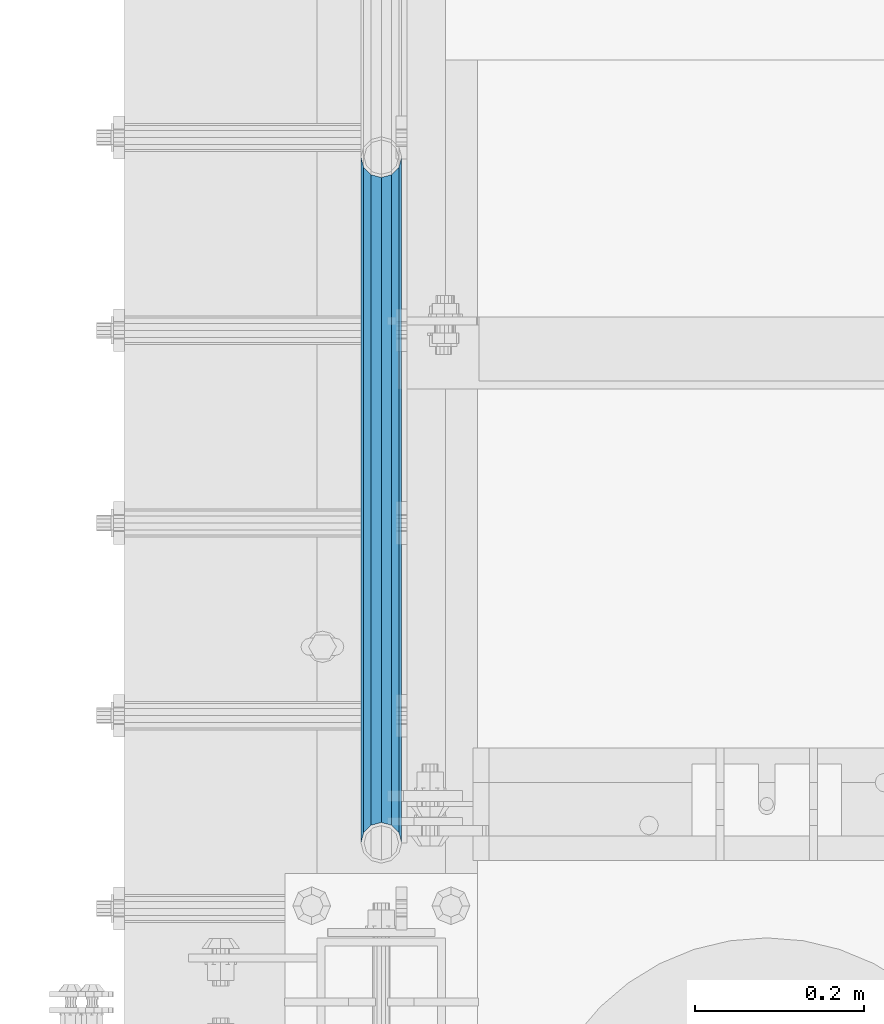
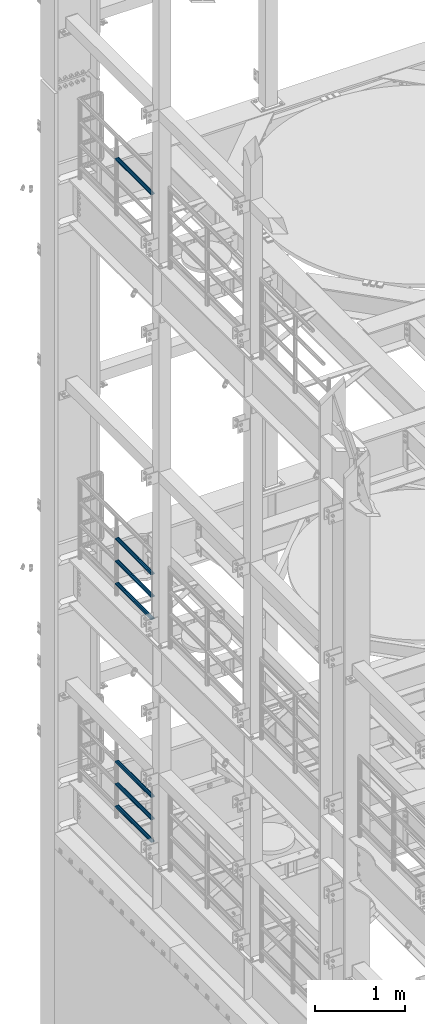
# One storey, part 1312 of 1876: 7 beams, 3 elements without a shape of their own.
"""IFC2X3 building model written with IfcOpenShell, lengths in millimetres."""

from ifc_helpers import new_model, si_unit, frame, origin_with_axes, place, context, subcontext, project, spatial, faceted_brep, material, type_object, element, aggregate, save


model = new_model("IFC2X3")

# Units and contexts
model_context = context("Model", 3, precision=1e-05, world=origin_with_axes())
body_context = subcontext(model_context, "Body", "Model", "MODEL_VIEW")
ifc_project = project(units=[si_unit("LENGTHUNIT", "METRE", prefix="MILLI"), si_unit("AREAUNIT", "SQUARE_METRE"), si_unit("VOLUMEUNIT", "CUBIC_METRE"), si_unit("MASSUNIT", "GRAM", prefix="KILO"), si_unit("TIMEUNIT", "SECOND"), si_unit("PLANEANGLEUNIT", "RADIAN"), si_unit("SOLIDANGLEUNIT", "STERADIAN"), si_unit("THERMODYNAMICTEMPERATUREUNIT", "DEGREE_CELSIUS"), si_unit("LUMINOUSINTENSITYUNIT", "LUMEN")], contexts=[model_context])

# Site, building, storey
site_placement = place(None, origin_with_axes())
site = spatial("IfcSite", under=ifc_project, at=site_placement, CompositionType="ELEMENT")
building_placement = place(site_placement, origin_with_axes())
building = spatial("IfcBuilding", under=site, at=building_placement, Name="Undefined", CompositionType="ELEMENT")
storey_placement = place(building_placement, origin_with_axes())
storey = spatial("IfcBuildingStorey", under=building, at=storey_placement, Name="Undefined", CompositionType="ELEMENT", Elevation=0.0)

# Assembly, beam
assembly_1_placement = place(storey_placement, origin_with_axes())
assembly_1 = element("IfcElementAssembly", 1, at=assembly_1_placement, inside=storey, Name="RAIL", AssemblyPlace="NOTDEFINED", PredefinedType="RIGID_FRAME")
ifc_material = material()
beam_type = type_object("IfcBeamType", Name="PIPE1-1/2SCH40", PredefinedType="NOTDEFINED")
beam_1_placement = place(assembly_1_placement, frame((-3.11501935357228e-11, 11872.9125, 14081.125), z_axis=(0.0, 0.0, -1.0), x_axis=(0.0, 1.0, 0.0)))
beam_1 = element("IfcBeam", 2, at=beam_1_placement, type_object=beam_type, material=ifc_material, Name="RAIL", ObjectType="PIPE1-1/2SCH40", context=body_context, shape_type="Brep", body=[
    faceted_brep([(0.0, 24.1299999999992, 0.0), (12.0650000000064, 20.8971929933177, -12.0649999999987), (12.0650000000064, 20.8971929933177, 12.0649999999987), (12.0650000000064, -20.8971929933177, 12.0649999999987), (12.0650000000064, -20.8971929933177, -12.0649999999987), (0.0, -24.1299999999992, 0.0), (20.8971929933249, -12.0650000000005, 20.8971929933177), (20.8971929933249, -12.0650000000005, 15.8661214311796), (15.2545715621445, -17.7076214311801, 10.2235000000001), (12.5151929933249, -20.4470000000001, 0.0), (15.2545715621445, -17.7076214311801, -10.2235000000001), (20.8971929933249, -12.0650000000005, -15.8661214311796), (20.8971929933249, -12.0650000000005, -20.8971929933177), (24.1300000000063, 0.0, -20.4470000000001), (24.1300000000063, 0.0, -24.130000000001), (21.3906214311868, -10.2235000000001, -17.7076214311819), (21.3906214311868, 10.2235000000001, -17.7076214311819), (20.8971929933249, 12.0650000000005, -15.8661214311796), (20.8971929933249, 12.0650000000005, -20.8971929933177), (15.2545715621445, 17.7076214311801, -10.2235000000001), (12.5151929933249, 20.4470000000001, 0.0), (15.2545715621445, 17.7076214311801, 10.2235000000001), (20.8971929933249, 12.0650000000005, 15.8661214311796), (20.8971929933249, 12.0650000000005, 20.8971929933177), (21.3906214311868, 10.2235000000001, 17.7076214311819), (24.1300000000064, 0.0, 20.4470000000001), (24.1300000000064, 0.0, 24.130000000001), (21.3906214311868, -10.2235000000001, 17.7076214311819), (813.396900000002, 24.1300000000001, 0.0), (801.331900000001, 20.8971929933186, -12.0649999999987), (792.499707006684, 12.0649999999996, -20.8971929933177), (813.396900000002, -24.1300000000319, 0.0), (801.331900000001, -20.8971929933186, -12.0649999999987), (801.331900000001, -20.8971929933186, 12.0649999999987), (792.499707006684, -12.0649999999996, 20.8971929933177), (792.499707006684, -12.0649999999996, -20.8971929933177), (789.266900000001, 0.0, -24.130000000001), (792.00627856883, 10.2235000000001, -17.7076214311819), (789.266900000001, 0.0, -20.4470000000001), (792.499707006684, 12.0649999999678, -15.8661214312124), (792.499707006684, -12.0650000000314, -15.8661214311469), (792.006278568813, -10.2235000000001, -17.7076214311819), (798.142328437831, -17.7076214311801, -10.2235000000001), (800.881707006651, -20.4470000000001, 0.0), (798.142328437831, -17.7076214311801, 10.2235000000001), (792.499707006684, -12.0650000000314, 15.8661214311469), (792.006278568813, -10.2235000000001, 17.7076214311819), (789.266900000001, -9.09494701772928e-13, 20.4470000000001), (789.266900000001, -9.09494701772928e-13, 24.130000000001), (792.499707006684, 12.0649999999996, 20.8971929933177), (801.331900000001, 20.8971929933186, 12.0649999999987), (792.499707006684, 12.0649999999678, 15.8661214312124), (798.142328437896, 17.7076214311801, 10.2235000000001), (800.881707006714, 20.4470000000001, 0.0), (798.142328437896, 17.7076214311801, -10.2235000000001), (792.00627856883, 10.2235000000001, 17.7076214311819)], [[[0, 1, 2]], [[3, 4, 5]], [[6, 7, 8, 9, 10, 11, 12, 4, 3]], [[13, 14, 12, 11, 15]], [[16, 17, 18, 14, 13]], [[2, 1, 18, 17, 19, 20, 21, 22, 23]], [[23, 22, 24, 25, 26]], [[26, 25, 27, 7, 6]], [[1, 0, 28, 29]], [[18, 1, 29, 30]], [[31, 32, 33]], [[6, 3, 33, 34]], [[3, 5, 31, 33]], [[5, 4, 32, 31]], [[4, 12, 35, 32]], [[12, 14, 36, 35]], [[14, 18, 30, 36]], [[37, 38, 36, 30, 39]], [[40, 35, 36, 38, 41]], [[33, 32, 35, 40, 42, 43, 44, 45, 34]], [[34, 45, 46, 47, 48]], [[26, 6, 34, 48]], [[2, 23, 49, 50]], [[23, 26, 48, 49]], [[0, 2, 50, 28]], [[28, 50, 29]], [[49, 51, 52, 53, 54, 39, 30, 29, 50]], [[48, 47, 55, 51, 49]], [[25, 24, 55, 47]], [[55, 24, 22, 21, 52, 51]], [[21, 20, 53, 52]], [[20, 19, 54, 53]], [[19, 17, 16, 37, 39, 54]], [[16, 13, 38, 37]], [[13, 15, 41, 38]], [[41, 15, 11, 10, 42, 40]], [[10, 9, 43, 42]], [[9, 8, 44, 43]], [[8, 7, 27, 46, 45, 44]], [[27, 25, 47, 46]]]),
])
aggregate(assembly_1, [beam_1])

# Assembly, beams
assembly_2_placement = place(storey_placement, origin_with_axes())
assembly_2 = element("IfcElementAssembly", 3, at=assembly_2_placement, inside=storey, Name="RAIL", AssemblyPlace="NOTDEFINED", PredefinedType="RIGID_FRAME")
beam_2_placement = place(assembly_2_placement, frame((-3.02406988339499e-11, 12686.3094, 8315.325), z_axis=(0.0, 0.0, 1.0), x_axis=(0.0, -1.0, 0.0)))
beam_2 = element("IfcBeam", 4, at=beam_2_placement, type_object=beam_type, material=ifc_material, Name="RAIL", ObjectType="PIPE1-1/2SCH40", context=body_context, shape_type="Brep", body=[
    faceted_brep([(792.499707006684, -12.0649999999996, 20.8971929933177), (792.499707006684, -12.0650000000314, 15.8661214311469), (792.006278568813, -10.2235000000001, 17.7076214311819), (789.266900000001, -9.09494701772928e-13, 20.4470000000001), (789.266900000001, -9.09494701772928e-13, 24.130000000001), (792.00627856883, 10.2235000000001, 17.7076214311819), (792.499707006684, 12.0649999999678, 15.8661214312124), (792.499707006684, 12.0649999999996, 20.8971929933177), (813.396900000002, 24.1300000000001, 0.0), (801.331900000001, 20.8971929933186, 12.0649999999987), (801.331900000001, 20.8971929933186, -12.0649999999987), (798.142328437896, 17.7076214311801, 10.2235000000001), (800.881707006714, 20.4470000000001, 0.0), (798.142328437896, 17.7076214311801, -10.2235000000001), (792.499707006684, 12.0649999999678, -15.8661214312124), (792.499707006684, 12.0649999999996, -20.8971929933177), (792.00627856883, 10.2235000000001, -17.7076214311819), (789.266900000001, 0.0, -20.4470000000001), (789.266900000001, 0.0, -24.130000000001), (792.499707006684, -12.0650000000314, -15.8661214311469), (792.499707006684, -12.0649999999996, -20.8971929933177), (792.006278568813, -10.2235000000001, -17.7076214311819), (813.396900000002, -24.1300000000319, 0.0), (801.331900000001, -20.8971929933186, -12.0649999999987), (801.331900000001, -20.8971929933186, 12.0649999999987), (798.142328437831, -17.7076214311801, -10.2235000000001), (800.881707006651, -20.4470000000001, 0.0), (798.142328437831, -17.7076214311801, 10.2235000000001), (12.0650000000064, -20.8971929933177, -12.0649999999987), (20.8971929933249, -12.0650000000005, -20.8971929933177), (0.0, 24.1299999999992, 0.0), (12.0650000000064, 20.8971929933177, -12.0649999999987), (12.0650000000064, 20.8971929933177, 12.0649999999987), (20.8971929933249, 12.0650000000005, 20.8971929933177), (24.1300000000064, 0.0, 24.130000000001), (20.8971929933249, 12.0650000000005, -20.8971929933177), (24.1300000000063, 0.0, -24.130000000001), (24.1300000000063, 0.0, -20.4470000000001), (20.8971929933249, -12.0650000000005, -15.8661214311796), (21.3906214311868, -10.2235000000001, -17.7076214311819), (21.3906214311868, 10.2235000000001, -17.7076214311819), (20.8971929933249, 12.0650000000005, -15.8661214311796), (15.2545715621445, 17.7076214311801, -10.2235000000001), (12.5151929933249, 20.4470000000001, 0.0), (15.2545715621445, 17.7076214311801, 10.2235000000001), (20.8971929933249, 12.0650000000005, 15.8661214311796), (21.3906214311868, 10.2235000000001, 17.7076214311819), (24.1300000000064, 0.0, 20.4470000000001), (21.3906214311868, -10.2235000000001, 17.7076214311819), (20.8971929933249, -12.0650000000005, 15.8661214311796), (20.8971929933249, -12.0650000000005, 20.8971929933177), (12.0650000000064, -20.8971929933177, 12.0649999999987), (0.0, -24.1299999999992, 0.0), (15.2545715621445, -17.7076214311801, 10.2235000000001), (12.5151929933249, -20.4470000000001, 0.0), (15.2545715621445, -17.7076214311801, -10.2235000000001)], [[[0, 1, 2, 3, 4]], [[4, 3, 5, 6, 7]], [[8, 9, 10]], [[7, 6, 11, 12, 13, 14, 15, 10, 9]], [[16, 17, 18, 15, 14]], [[19, 20, 18, 17, 21]], [[22, 23, 24]], [[24, 23, 20, 19, 25, 26, 27, 1, 0]], [[28, 29, 20, 23]], [[30, 31, 32]], [[33, 34, 4, 7]], [[32, 33, 7, 9]], [[30, 32, 9, 8]], [[31, 30, 8, 10]], [[35, 31, 10, 15]], [[36, 35, 15, 18]], [[29, 36, 18, 20]], [[37, 36, 29, 38, 39]], [[40, 41, 35, 36, 37]], [[32, 31, 35, 41, 42, 43, 44, 45, 33]], [[33, 45, 46, 47, 34]], [[34, 47, 48, 49, 50]], [[34, 50, 0, 4]], [[50, 51, 24, 0]], [[51, 52, 22, 24]], [[52, 28, 23, 22]], [[51, 28, 52]], [[50, 49, 53, 54, 55, 38, 29, 28, 51]], [[55, 54, 26, 25]], [[21, 39, 38, 55, 25, 19]], [[37, 39, 21, 17]], [[40, 37, 17, 16]], [[42, 41, 40, 16, 14, 13]], [[43, 42, 13, 12]], [[44, 43, 12, 11]], [[5, 46, 45, 44, 11, 6]], [[47, 46, 5, 3]], [[48, 47, 3, 2]], [[53, 49, 48, 2, 1, 27]], [[54, 53, 27, 26]]]),
])
beam_3_placement = place(assembly_2_placement, frame((-3.11501935357228e-11, 11872.9125, 8620.125), z_axis=(0.0, 0.0, -1.0), x_axis=(0.0, 1.0, 0.0)))
beam_3 = element("IfcBeam", 5, at=beam_3_placement, type_object=beam_type, material=ifc_material, Name="RAIL", ObjectType="PIPE1-1/2SCH40", context=body_context, shape_type="Brep", body=[
    faceted_brep([(0.0, 24.1299999999992, 0.0), (12.0650000000064, 20.8971929933177, -12.0649999999987), (12.0650000000064, 20.8971929933177, 12.0649999999987), (12.0650000000064, -20.8971929933177, 12.0649999999987), (12.0650000000064, -20.8971929933177, -12.0649999999987), (0.0, -24.1299999999992, 0.0), (20.8971929933249, -12.0650000000005, 20.8971929933177), (20.8971929933249, -12.0650000000005, 15.8661214311796), (15.2545715621445, -17.7076214311801, 10.2235000000001), (12.5151929933249, -20.4470000000001, 0.0), (15.2545715621445, -17.7076214311801, -10.2235000000001), (20.8971929933249, -12.0650000000005, -15.8661214311796), (20.8971929933249, -12.0650000000005, -20.8971929933177), (24.1300000000063, 0.0, -20.4470000000001), (24.1300000000063, 0.0, -24.130000000001), (21.3906214311868, -10.2235000000001, -17.7076214311819), (21.3906214311868, 10.2235000000001, -17.7076214311819), (20.8971929933249, 12.0650000000005, -15.8661214311796), (20.8971929933249, 12.0650000000005, -20.8971929933177), (15.2545715621445, 17.7076214311801, -10.2235000000001), (12.5151929933249, 20.4470000000001, 0.0), (15.2545715621445, 17.7076214311801, 10.2235000000001), (20.8971929933249, 12.0650000000005, 15.8661214311796), (20.8971929933249, 12.0650000000005, 20.8971929933177), (21.3906214311868, 10.2235000000001, 17.7076214311819), (24.1300000000064, 0.0, 20.4470000000001), (24.1300000000064, 0.0, 24.130000000001), (21.3906214311868, -10.2235000000001, 17.7076214311819), (813.396900000002, 24.1300000000001, 0.0), (801.331900000001, 20.8971929933186, -12.0649999999987), (792.499707006684, 12.0649999999996, -20.8971929933177), (813.396900000002, -24.1300000000319, 0.0), (801.331900000001, -20.8971929933186, -12.0649999999987), (801.331900000001, -20.8971929933186, 12.0649999999987), (792.499707006684, -12.0649999999996, 20.8971929933177), (792.499707006684, -12.0649999999996, -20.8971929933177), (789.266900000001, 0.0, -24.130000000001), (792.00627856883, 10.2235000000001, -17.7076214311819), (789.266900000001, 0.0, -20.4470000000001), (792.499707006684, 12.0649999999678, -15.8661214312124), (792.499707006684, -12.0650000000314, -15.8661214311469), (792.006278568813, -10.2235000000001, -17.7076214311819), (798.142328437831, -17.7076214311801, -10.2235000000001), (800.881707006651, -20.4470000000001, 0.0), (798.142328437831, -17.7076214311801, 10.2235000000001), (792.499707006684, -12.0650000000314, 15.8661214311469), (792.006278568813, -10.2235000000001, 17.7076214311819), (789.266900000001, -9.09494701772928e-13, 20.4470000000001), (789.266900000001, -9.09494701772928e-13, 24.130000000001), (792.499707006684, 12.0649999999996, 20.8971929933177), (801.331900000001, 20.8971929933186, 12.0649999999987), (792.499707006684, 12.0649999999678, 15.8661214312124), (798.142328437896, 17.7076214311801, 10.2235000000001), (800.881707006714, 20.4470000000001, 0.0), (798.142328437896, 17.7076214311801, -10.2235000000001), (792.00627856883, 10.2235000000001, 17.7076214311819)], [[[0, 1, 2]], [[3, 4, 5]], [[6, 7, 8, 9, 10, 11, 12, 4, 3]], [[13, 14, 12, 11, 15]], [[16, 17, 18, 14, 13]], [[2, 1, 18, 17, 19, 20, 21, 22, 23]], [[23, 22, 24, 25, 26]], [[26, 25, 27, 7, 6]], [[1, 0, 28, 29]], [[18, 1, 29, 30]], [[31, 32, 33]], [[6, 3, 33, 34]], [[3, 5, 31, 33]], [[5, 4, 32, 31]], [[4, 12, 35, 32]], [[12, 14, 36, 35]], [[14, 18, 30, 36]], [[37, 38, 36, 30, 39]], [[40, 35, 36, 38, 41]], [[33, 32, 35, 40, 42, 43, 44, 45, 34]], [[34, 45, 46, 47, 48]], [[26, 6, 34, 48]], [[2, 23, 49, 50]], [[23, 26, 48, 49]], [[0, 2, 50, 28]], [[28, 50, 29]], [[49, 51, 52, 53, 54, 39, 30, 29, 50]], [[48, 47, 55, 51, 49]], [[25, 24, 55, 47]], [[55, 24, 22, 21, 52, 51]], [[21, 20, 53, 52]], [[20, 19, 54, 53]], [[19, 17, 16, 37, 39, 54]], [[16, 13, 38, 37]], [[13, 15, 41, 38]], [[41, 15, 11, 10, 42, 40]], [[10, 9, 43, 42]], [[9, 8, 44, 43]], [[8, 7, 27, 46, 45, 44]], [[27, 25, 47, 46]]]),
])
beam_4_placement = place(assembly_2_placement, frame((-3.11501935357228e-11, 11872.9125, 8924.925), z_axis=(0.0, 0.0, -1.0), x_axis=(0.0, 1.0, 0.0)))
beam_4 = element("IfcBeam", 6, at=beam_4_placement, type_object=beam_type, material=ifc_material, Name="RAIL", ObjectType="PIPE1-1/2SCH40", context=body_context, shape_type="Brep", body=[
    faceted_brep([(0.0, 24.1299999999992, 0.0), (12.0650000000064, 20.8971929933177, -12.0649999999987), (12.0650000000064, 20.8971929933177, 12.0649999999987), (12.0650000000064, -20.8971929933177, 12.0649999999987), (12.0650000000064, -20.8971929933177, -12.0649999999987), (0.0, -24.1299999999992, 0.0), (20.8971929933249, -12.0650000000005, 20.8971929933177), (20.8971929933249, -12.0650000000005, 15.8661214311796), (15.2545715621445, -17.7076214311801, 10.2235000000001), (12.5151929933249, -20.4470000000001, 0.0), (15.2545715621445, -17.7076214311801, -10.2235000000001), (20.8971929933249, -12.0650000000005, -15.8661214311796), (20.8971929933249, -12.0650000000005, -20.8971929933177), (24.1300000000063, 0.0, -20.4470000000001), (24.1300000000063, 0.0, -24.130000000001), (21.3906214311868, -10.2235000000001, -17.7076214311819), (21.3906214311868, 10.2235000000001, -17.7076214311819), (20.8971929933249, 12.0650000000005, -15.8661214311796), (20.8971929933249, 12.0650000000005, -20.8971929933177), (15.2545715621445, 17.7076214311801, -10.2235000000001), (12.5151929933249, 20.4470000000001, 0.0), (15.2545715621445, 17.7076214311801, 10.2235000000001), (20.8971929933249, 12.0650000000005, 15.8661214311796), (20.8971929933249, 12.0650000000005, 20.8971929933177), (21.3906214311868, 10.2235000000001, 17.7076214311819), (24.1300000000064, 0.0, 20.4470000000001), (24.1300000000064, 0.0, 24.130000000001), (21.3906214311868, -10.2235000000001, 17.7076214311819), (813.396900000002, 24.1300000000001, 0.0), (801.331900000001, 20.8971929933186, -12.0649999999987), (792.499707006684, 12.0649999999996, -20.8971929933177), (813.396900000002, -24.1300000000319, 0.0), (801.331900000001, -20.8971929933186, -12.0649999999987), (801.331900000001, -20.8971929933186, 12.0649999999987), (792.499707006684, -12.0649999999996, 20.8971929933177), (792.499707006684, -12.0649999999996, -20.8971929933177), (789.266900000001, 0.0, -24.130000000001), (792.00627856883, 10.2235000000001, -17.7076214311819), (789.266900000001, 0.0, -20.4470000000001), (792.499707006684, 12.0649999999678, -15.8661214312124), (792.499707006684, -12.0650000000314, -15.8661214311469), (792.006278568813, -10.2235000000001, -17.7076214311819), (798.142328437831, -17.7076214311801, -10.2235000000001), (800.881707006651, -20.4470000000001, 0.0), (798.142328437831, -17.7076214311801, 10.2235000000001), (792.499707006684, -12.0650000000314, 15.8661214311469), (792.006278568813, -10.2235000000001, 17.7076214311819), (789.266900000001, -9.09494701772928e-13, 20.4470000000001), (789.266900000001, -9.09494701772928e-13, 24.130000000001), (792.499707006684, 12.0649999999996, 20.8971929933177), (801.331900000001, 20.8971929933186, 12.0649999999987), (792.499707006684, 12.0649999999678, 15.8661214312124), (798.142328437896, 17.7076214311801, 10.2235000000001), (800.881707006714, 20.4470000000001, 0.0), (798.142328437896, 17.7076214311801, -10.2235000000001), (792.00627856883, 10.2235000000001, 17.7076214311819)], [[[0, 1, 2]], [[3, 4, 5]], [[6, 7, 8, 9, 10, 11, 12, 4, 3]], [[13, 14, 12, 11, 15]], [[16, 17, 18, 14, 13]], [[2, 1, 18, 17, 19, 20, 21, 22, 23]], [[23, 22, 24, 25, 26]], [[26, 25, 27, 7, 6]], [[1, 0, 28, 29]], [[18, 1, 29, 30]], [[31, 32, 33]], [[6, 3, 33, 34]], [[3, 5, 31, 33]], [[5, 4, 32, 31]], [[4, 12, 35, 32]], [[12, 14, 36, 35]], [[14, 18, 30, 36]], [[37, 38, 36, 30, 39]], [[40, 35, 36, 38, 41]], [[33, 32, 35, 40, 42, 43, 44, 45, 34]], [[34, 45, 46, 47, 48]], [[26, 6, 34, 48]], [[2, 23, 49, 50]], [[23, 26, 48, 49]], [[0, 2, 50, 28]], [[28, 50, 29]], [[49, 51, 52, 53, 54, 39, 30, 29, 50]], [[48, 47, 55, 51, 49]], [[25, 24, 55, 47]], [[55, 24, 22, 21, 52, 51]], [[21, 20, 53, 52]], [[20, 19, 54, 53]], [[19, 17, 16, 37, 39, 54]], [[16, 13, 38, 37]], [[13, 15, 41, 38]], [[41, 15, 11, 10, 42, 40]], [[10, 9, 43, 42]], [[9, 8, 44, 43]], [[8, 7, 27, 46, 45, 44]], [[27, 25, 47, 46]]]),
])
aggregate(assembly_2, [beam_2, beam_3, beam_4])

assembly_3_placement = place(storey_placement, origin_with_axes())
assembly_3 = element("IfcElementAssembly", 7, at=assembly_3_placement, inside=storey, Name="RAIL", AssemblyPlace="NOTDEFINED", PredefinedType="RIGID_FRAME")
beam_5_placement = place(assembly_3_placement, frame((-3.02406988339499e-11, 12686.3094, 5292.725), z_axis=(0.0, 0.0, 1.0), x_axis=(0.0, -1.0, 0.0)))
beam_5 = element("IfcBeam", 8, at=beam_5_placement, type_object=beam_type, material=ifc_material, Name="RAIL", ObjectType="PIPE1-1/2SCH40", context=body_context, shape_type="Brep", body=[
    faceted_brep([(792.499707006684, -12.0649999999996, 20.8971929933177), (792.499707006684, -12.0650000000314, 15.8661214311469), (792.006278568813, -10.2235000000001, 17.7076214311819), (789.266900000001, -9.09494701772928e-13, 20.4470000000001), (789.266900000001, -9.09494701772928e-13, 24.130000000001), (792.00627856883, 10.2235000000001, 17.7076214311819), (792.499707006684, 12.0649999999678, 15.8661214312124), (792.499707006684, 12.0649999999996, 20.8971929933177), (813.396900000002, 24.1300000000001, 0.0), (801.331900000001, 20.8971929933186, 12.0649999999987), (801.331900000001, 20.8971929933186, -12.0649999999987), (798.142328437896, 17.7076214311801, 10.2235000000001), (800.881707006714, 20.4470000000001, 0.0), (798.142328437896, 17.7076214311801, -10.2235000000001), (792.499707006684, 12.0649999999678, -15.8661214312124), (792.499707006684, 12.0649999999996, -20.8971929933177), (792.00627856883, 10.2235000000001, -17.7076214311819), (789.266900000001, 0.0, -20.4470000000001), (789.266900000001, 0.0, -24.130000000001), (792.499707006684, -12.0650000000314, -15.8661214311469), (792.499707006684, -12.0649999999996, -20.8971929933177), (792.006278568813, -10.2235000000001, -17.7076214311819), (813.396900000002, -24.1300000000319, 0.0), (801.331900000001, -20.8971929933186, -12.0649999999987), (801.331900000001, -20.8971929933186, 12.0649999999987), (798.142328437831, -17.7076214311801, -10.2235000000001), (800.881707006651, -20.4470000000001, 0.0), (798.142328437831, -17.7076214311801, 10.2235000000001), (12.0650000000064, -20.8971929933177, -12.0649999999987), (20.8971929933249, -12.0650000000005, -20.8971929933177), (0.0, 24.1299999999992, 0.0), (12.0650000000064, 20.8971929933177, -12.0649999999987), (12.0650000000064, 20.8971929933177, 12.0649999999987), (20.8971929933249, 12.0650000000005, 20.8971929933177), (24.1300000000064, 0.0, 24.130000000001), (20.8971929933249, 12.0650000000005, -20.8971929933177), (24.1300000000063, 0.0, -24.130000000001), (24.1300000000063, 0.0, -20.4470000000001), (20.8971929933249, -12.0650000000005, -15.8661214311796), (21.3906214311868, -10.2235000000001, -17.7076214311819), (21.3906214311868, 10.2235000000001, -17.7076214311819), (20.8971929933249, 12.0650000000005, -15.8661214311796), (15.2545715621445, 17.7076214311801, -10.2235000000001), (12.5151929933249, 20.4470000000001, 0.0), (15.2545715621445, 17.7076214311801, 10.2235000000001), (20.8971929933249, 12.0650000000005, 15.8661214311796), (21.3906214311868, 10.2235000000001, 17.7076214311819), (24.1300000000064, 0.0, 20.4470000000001), (21.3906214311868, -10.2235000000001, 17.7076214311819), (20.8971929933249, -12.0650000000005, 15.8661214311796), (20.8971929933249, -12.0650000000005, 20.8971929933177), (12.0650000000064, -20.8971929933177, 12.0649999999987), (0.0, -24.1299999999992, 0.0), (15.2545715621445, -17.7076214311801, 10.2235000000001), (12.5151929933249, -20.4470000000001, 0.0), (15.2545715621445, -17.7076214311801, -10.2235000000001)], [[[0, 1, 2, 3, 4]], [[4, 3, 5, 6, 7]], [[8, 9, 10]], [[7, 6, 11, 12, 13, 14, 15, 10, 9]], [[16, 17, 18, 15, 14]], [[19, 20, 18, 17, 21]], [[22, 23, 24]], [[24, 23, 20, 19, 25, 26, 27, 1, 0]], [[28, 29, 20, 23]], [[30, 31, 32]], [[33, 34, 4, 7]], [[32, 33, 7, 9]], [[30, 32, 9, 8]], [[31, 30, 8, 10]], [[35, 31, 10, 15]], [[36, 35, 15, 18]], [[29, 36, 18, 20]], [[37, 36, 29, 38, 39]], [[40, 41, 35, 36, 37]], [[32, 31, 35, 41, 42, 43, 44, 45, 33]], [[33, 45, 46, 47, 34]], [[34, 47, 48, 49, 50]], [[34, 50, 0, 4]], [[50, 51, 24, 0]], [[51, 52, 22, 24]], [[52, 28, 23, 22]], [[51, 28, 52]], [[50, 49, 53, 54, 55, 38, 29, 28, 51]], [[55, 54, 26, 25]], [[21, 39, 38, 55, 25, 19]], [[37, 39, 21, 17]], [[40, 37, 17, 16]], [[42, 41, 40, 16, 14, 13]], [[43, 42, 13, 12]], [[44, 43, 12, 11]], [[5, 46, 45, 44, 11, 6]], [[47, 46, 5, 3]], [[48, 47, 3, 2]], [[53, 49, 48, 2, 1, 27]], [[54, 53, 27, 26]]]),
])
beam_6_placement = place(assembly_3_placement, frame((-3.11501935357228e-11, 11872.9125, 5597.525), z_axis=(0.0, 0.0, -1.0), x_axis=(0.0, 1.0, 0.0)))
beam_6 = element("IfcBeam", 9, at=beam_6_placement, type_object=beam_type, material=ifc_material, Name="RAIL", ObjectType="PIPE1-1/2SCH40", context=body_context, shape_type="Brep", body=[
    faceted_brep([(0.0, 24.1299999999992, 0.0), (12.0650000000064, 20.8971929933177, -12.0649999999987), (12.0650000000064, 20.8971929933177, 12.0649999999987), (12.0650000000064, -20.8971929933177, 12.0649999999987), (12.0650000000064, -20.8971929933177, -12.0649999999987), (0.0, -24.1299999999992, 0.0), (20.8971929933249, -12.0650000000005, 20.8971929933177), (20.8971929933249, -12.0650000000005, 15.8661214311796), (15.2545715621445, -17.7076214311801, 10.2235000000001), (12.5151929933249, -20.4470000000001, 0.0), (15.2545715621445, -17.7076214311801, -10.2235000000001), (20.8971929933249, -12.0650000000005, -15.8661214311796), (20.8971929933249, -12.0650000000005, -20.8971929933177), (24.1300000000063, 0.0, -20.4470000000001), (24.1300000000063, 0.0, -24.130000000001), (21.3906214311868, -10.2235000000001, -17.7076214311819), (21.3906214311868, 10.2235000000001, -17.7076214311819), (20.8971929933249, 12.0650000000005, -15.8661214311796), (20.8971929933249, 12.0650000000005, -20.8971929933177), (15.2545715621445, 17.7076214311801, -10.2235000000001), (12.5151929933249, 20.4470000000001, 0.0), (15.2545715621445, 17.7076214311801, 10.2235000000001), (20.8971929933249, 12.0650000000005, 15.8661214311796), (20.8971929933249, 12.0650000000005, 20.8971929933177), (21.3906214311868, 10.2235000000001, 17.7076214311819), (24.1300000000064, 0.0, 20.4470000000001), (24.1300000000064, 0.0, 24.130000000001), (21.3906214311868, -10.2235000000001, 17.7076214311819), (813.396900000002, 24.1300000000001, 0.0), (801.331900000001, 20.8971929933186, -12.0649999999987), (792.499707006684, 12.0649999999996, -20.8971929933177), (813.396900000002, -24.1300000000319, 0.0), (801.331900000001, -20.8971929933186, -12.0649999999987), (801.331900000001, -20.8971929933186, 12.0649999999987), (792.499707006684, -12.0649999999996, 20.8971929933177), (792.499707006684, -12.0649999999996, -20.8971929933177), (789.266900000001, 0.0, -24.130000000001), (792.00627856883, 10.2235000000001, -17.7076214311819), (789.266900000001, 0.0, -20.4470000000001), (792.499707006684, 12.0649999999678, -15.8661214312124), (792.499707006684, -12.0650000000314, -15.8661214311469), (792.006278568813, -10.2235000000001, -17.7076214311819), (798.142328437831, -17.7076214311801, -10.2235000000001), (800.881707006651, -20.4470000000001, 0.0), (798.142328437831, -17.7076214311801, 10.2235000000001), (792.499707006684, -12.0650000000314, 15.8661214311469), (792.006278568813, -10.2235000000001, 17.7076214311819), (789.266900000001, -9.09494701772928e-13, 20.4470000000001), (789.266900000001, -9.09494701772928e-13, 24.130000000001), (792.499707006684, 12.0649999999996, 20.8971929933177), (801.331900000001, 20.8971929933186, 12.0649999999987), (792.499707006684, 12.0649999999678, 15.8661214312124), (798.142328437896, 17.7076214311801, 10.2235000000001), (800.881707006714, 20.4470000000001, 0.0), (798.142328437896, 17.7076214311801, -10.2235000000001), (792.00627856883, 10.2235000000001, 17.7076214311819)], [[[0, 1, 2]], [[3, 4, 5]], [[6, 7, 8, 9, 10, 11, 12, 4, 3]], [[13, 14, 12, 11, 15]], [[16, 17, 18, 14, 13]], [[2, 1, 18, 17, 19, 20, 21, 22, 23]], [[23, 22, 24, 25, 26]], [[26, 25, 27, 7, 6]], [[1, 0, 28, 29]], [[18, 1, 29, 30]], [[31, 32, 33]], [[6, 3, 33, 34]], [[3, 5, 31, 33]], [[5, 4, 32, 31]], [[4, 12, 35, 32]], [[12, 14, 36, 35]], [[14, 18, 30, 36]], [[37, 38, 36, 30, 39]], [[40, 35, 36, 38, 41]], [[33, 32, 35, 40, 42, 43, 44, 45, 34]], [[34, 45, 46, 47, 48]], [[26, 6, 34, 48]], [[2, 23, 49, 50]], [[23, 26, 48, 49]], [[0, 2, 50, 28]], [[28, 50, 29]], [[49, 51, 52, 53, 54, 39, 30, 29, 50]], [[48, 47, 55, 51, 49]], [[25, 24, 55, 47]], [[55, 24, 22, 21, 52, 51]], [[21, 20, 53, 52]], [[20, 19, 54, 53]], [[19, 17, 16, 37, 39, 54]], [[16, 13, 38, 37]], [[13, 15, 41, 38]], [[41, 15, 11, 10, 42, 40]], [[10, 9, 43, 42]], [[9, 8, 44, 43]], [[8, 7, 27, 46, 45, 44]], [[27, 25, 47, 46]]]),
])
beam_7_placement = place(assembly_3_placement, frame((-3.11501935357228e-11, 11872.9125, 5902.325), z_axis=(0.0, 0.0, -1.0), x_axis=(0.0, 1.0, 0.0)))
beam_7 = element("IfcBeam", 10, at=beam_7_placement, type_object=beam_type, material=ifc_material, Name="RAIL", ObjectType="PIPE1-1/2SCH40", context=body_context, shape_type="Brep", body=[
    faceted_brep([(0.0, 24.1299999999992, 0.0), (12.0650000000064, 20.8971929933177, -12.0649999999987), (12.0650000000064, 20.8971929933177, 12.0649999999987), (12.0650000000064, -20.8971929933177, 12.0649999999987), (12.0650000000064, -20.8971929933177, -12.0649999999987), (0.0, -24.1299999999992, 0.0), (20.8971929933249, -12.0650000000005, 20.8971929933177), (20.8971929933249, -12.0650000000005, 15.8661214311796), (15.2545715621445, -17.7076214311801, 10.2235000000001), (12.5151929933249, -20.4470000000001, 0.0), (15.2545715621445, -17.7076214311801, -10.2235000000001), (20.8971929933249, -12.0650000000005, -15.8661214311796), (20.8971929933249, -12.0650000000005, -20.8971929933177), (24.1300000000063, 0.0, -20.4470000000001), (24.1300000000063, 0.0, -24.130000000001), (21.3906214311868, -10.2235000000001, -17.7076214311819), (21.3906214311868, 10.2235000000001, -17.7076214311819), (20.8971929933249, 12.0650000000005, -15.8661214311796), (20.8971929933249, 12.0650000000005, -20.8971929933177), (15.2545715621445, 17.7076214311801, -10.2235000000001), (12.5151929933249, 20.4470000000001, 0.0), (15.2545715621445, 17.7076214311801, 10.2235000000001), (20.8971929933249, 12.0650000000005, 15.8661214311796), (20.8971929933249, 12.0650000000005, 20.8971929933177), (21.3906214311868, 10.2235000000001, 17.7076214311819), (24.1300000000064, 0.0, 20.4470000000001), (24.1300000000064, 0.0, 24.130000000001), (21.3906214311868, -10.2235000000001, 17.7076214311819), (813.396900000002, 24.1300000000001, 0.0), (801.331900000001, 20.8971929933186, -12.0649999999987), (792.499707006684, 12.0649999999996, -20.8971929933177), (813.396900000002, -24.1300000000319, 0.0), (801.331900000001, -20.8971929933186, -12.0649999999987), (801.331900000001, -20.8971929933186, 12.0649999999987), (792.499707006684, -12.0649999999996, 20.8971929933177), (792.499707006684, -12.0649999999996, -20.8971929933177), (789.266900000001, 0.0, -24.130000000001), (792.00627856883, 10.2235000000001, -17.7076214311819), (789.266900000001, 0.0, -20.4470000000001), (792.499707006684, 12.0649999999678, -15.8661214312124), (792.499707006684, -12.0650000000314, -15.8661214311469), (792.006278568813, -10.2235000000001, -17.7076214311819), (798.142328437831, -17.7076214311801, -10.2235000000001), (800.881707006651, -20.4470000000001, 0.0), (798.142328437831, -17.7076214311801, 10.2235000000001), (792.499707006684, -12.0650000000314, 15.8661214311469), (792.006278568813, -10.2235000000001, 17.7076214311819), (789.266900000001, -9.09494701772928e-13, 20.4470000000001), (789.266900000001, -9.09494701772928e-13, 24.130000000001), (792.499707006684, 12.0649999999996, 20.8971929933177), (801.331900000001, 20.8971929933186, 12.0649999999987), (792.499707006684, 12.0649999999678, 15.8661214312124), (798.142328437896, 17.7076214311801, 10.2235000000001), (800.881707006714, 20.4470000000001, 0.0), (798.142328437896, 17.7076214311801, -10.2235000000001), (792.00627856883, 10.2235000000001, 17.7076214311819)], [[[0, 1, 2]], [[3, 4, 5]], [[6, 7, 8, 9, 10, 11, 12, 4, 3]], [[13, 14, 12, 11, 15]], [[16, 17, 18, 14, 13]], [[2, 1, 18, 17, 19, 20, 21, 22, 23]], [[23, 22, 24, 25, 26]], [[26, 25, 27, 7, 6]], [[1, 0, 28, 29]], [[18, 1, 29, 30]], [[31, 32, 33]], [[6, 3, 33, 34]], [[3, 5, 31, 33]], [[5, 4, 32, 31]], [[4, 12, 35, 32]], [[12, 14, 36, 35]], [[14, 18, 30, 36]], [[37, 38, 36, 30, 39]], [[40, 35, 36, 38, 41]], [[33, 32, 35, 40, 42, 43, 44, 45, 34]], [[34, 45, 46, 47, 48]], [[26, 6, 34, 48]], [[2, 23, 49, 50]], [[23, 26, 48, 49]], [[0, 2, 50, 28]], [[28, 50, 29]], [[49, 51, 52, 53, 54, 39, 30, 29, 50]], [[48, 47, 55, 51, 49]], [[25, 24, 55, 47]], [[55, 24, 22, 21, 52, 51]], [[21, 20, 53, 52]], [[20, 19, 54, 53]], [[19, 17, 16, 37, 39, 54]], [[16, 13, 38, 37]], [[13, 15, 41, 38]], [[41, 15, 11, 10, 42, 40]], [[10, 9, 43, 42]], [[9, 8, 44, 43]], [[8, 7, 27, 46, 45, 44]], [[27, 25, 47, 46]]]),
])
aggregate(assembly_3, [beam_5, beam_6, beam_7])

save(model, "model.ifc")
